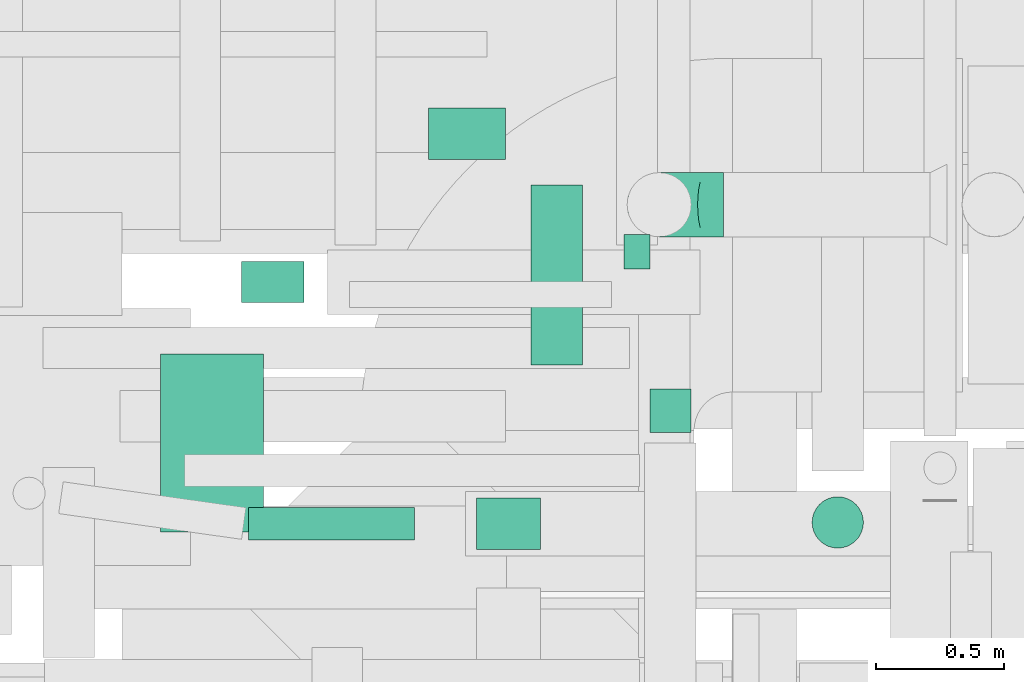
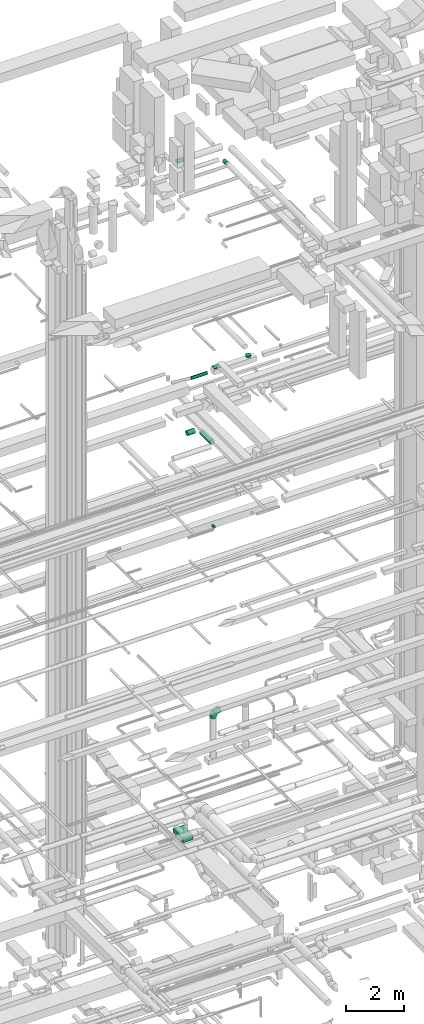
# One storey, part 274 of 337: 9 flow segments, 1 flow fitting.
"""IFC2X3 building model written with IfcOpenShell, lengths in millimetres."""

from ifc_helpers import new_model, entity, si_unit, converted_unit, derived_unit, direction, frame, origin, origin_2d_with_axis, place, context, subcontext, project, spatial, rectangle, circle, extrude, faceted_brep, source, transform, mapped, material, type_object, type_shapes, element, save


model = new_model("IFC2X3")

# Units and contexts
model_context = context("Model", 3, precision=0.01, world=origin(), true_north=direction((6.12303176911189e-17, 1.0)))
body_context = subcontext(model_context, "Body", "Model", "MODEL_VIEW")
ifc_project = project(units=[si_unit("LENGTHUNIT", "METRE", prefix="MILLI"), si_unit("AREAUNIT", "SQUARE_METRE"), si_unit("VOLUMEUNIT", "CUBIC_METRE"), converted_unit("PLANEANGLEUNIT", "DEGREE", entity("IfcRatioMeasure", 0.0174532925199433), si_unit("PLANEANGLEUNIT", "RADIAN"), dimensions=[0, 0, 0, 0, 0, 0, 0]), si_unit("MASSUNIT", "GRAM", prefix="KILO"), derived_unit("MASSDENSITYUNIT", [(si_unit("MASSUNIT", "GRAM", prefix="KILO"), 1), (si_unit("LENGTHUNIT", "METRE"), -3)]), derived_unit("MOMENTOFINERTIAUNIT", [(si_unit("LENGTHUNIT", "METRE"), 4)]), si_unit("TIMEUNIT", "SECOND"), si_unit("FREQUENCYUNIT", "HERTZ"), si_unit("THERMODYNAMICTEMPERATUREUNIT", "DEGREE_CELSIUS"), derived_unit("THERMALTRANSMITTANCEUNIT", [(si_unit("MASSUNIT", "GRAM", prefix="KILO"), 1), (si_unit("THERMODYNAMICTEMPERATUREUNIT", "KELVIN"), -1), (si_unit("TIMEUNIT", "SECOND"), -3)]), derived_unit("VOLUMETRICFLOWRATEUNIT", [(si_unit("LENGTHUNIT", "METRE"), 3), (si_unit("TIMEUNIT", "SECOND"), -1)]), derived_unit("MASSFLOWRATEUNIT", [(si_unit("MASSUNIT", "GRAM", prefix="KILO"), 1), (si_unit("TIMEUNIT", "SECOND"), -1)]), derived_unit("ROTATIONALFREQUENCYUNIT", [(si_unit("TIMEUNIT", "SECOND"), -1)]), si_unit("ELECTRICCURRENTUNIT", "AMPERE"), si_unit("ELECTRICVOLTAGEUNIT", "VOLT"), si_unit("POWERUNIT", "WATT"), si_unit("FORCEUNIT", "NEWTON", prefix="KILO"), si_unit("ILLUMINANCEUNIT", "LUX"), si_unit("LUMINOUSFLUXUNIT", "LUMEN"), si_unit("LUMINOUSINTENSITYUNIT", "CANDELA"), derived_unit("USERDEFINED", [(si_unit("MASSUNIT", "GRAM", prefix="KILO"), -1), (si_unit("LENGTHUNIT", "METRE"), -2), (si_unit("TIMEUNIT", "SECOND"), 3), (si_unit("LUMINOUSFLUXUNIT", "LUMEN"), 1)]), derived_unit("LINEARVELOCITYUNIT", [(si_unit("LENGTHUNIT", "METRE"), 1), (si_unit("TIMEUNIT", "SECOND"), -1)]), si_unit("PRESSUREUNIT", "PASCAL"), derived_unit("USERDEFINED", [(si_unit("LENGTHUNIT", "METRE"), -2), (si_unit("MASSUNIT", "GRAM", prefix="KILO"), 1), (si_unit("TIMEUNIT", "SECOND"), -2)]), derived_unit("LINEARFORCEUNIT", [(si_unit("MASSUNIT", "GRAM", prefix="KILO"), 1), (si_unit("LENGTHUNIT", "METRE"), 1), (si_unit("TIMEUNIT", "SECOND"), -2), (si_unit("LENGTHUNIT", "METRE"), -1)]), derived_unit("PLANARFORCEUNIT", [(si_unit("MASSUNIT", "GRAM", prefix="KILO"), 1), (si_unit("LENGTHUNIT", "METRE"), 1), (si_unit("TIMEUNIT", "SECOND"), -2), (si_unit("LENGTHUNIT", "METRE"), -2)])], contexts=[model_context])

# Site, building, storey
site_placement = place(None, origin())
site = spatial("IfcSite", under=ifc_project, at=site_placement, CompositionType="ELEMENT")
building_placement = place(site_placement, origin())
building = spatial("IfcBuilding", under=site, at=building_placement, CompositionType="ELEMENT")
storey_placement = place(building_placement, origin())
storey = spatial("IfcBuildingStorey", under=building, at=storey_placement, CompositionType="ELEMENT", Elevation=0.0)

# Flow segments
duct_segment_type_1 = type_object("IfcDuctSegmentType", PredefinedType="NOTDEFINED")
flow_segment_1_placement = place(storey_placement, frame((39339.82, 16031.71, 18970.0)))
element("IfcFlowSegment", 1, at=flow_segment_1_placement, inside=storey, type_object=duct_segment_type_1, context=body_context, shape_type="SweptSolid", body=[
    extrude(rectangle(XDim=249.999999999995, YDim=200.0, at=origin_2d_with_axis()), frame((125.0, 100.0, 0.0)), (0.0, 0.0, 1.0), 29.9999999999953),
])
flow_segment_2_placement = place(storey_placement, frame((38109.51, 16098.93, -700.0)))
element("IfcFlowSegment", 2, at=flow_segment_2_placement, inside=storey, type_object=duct_segment_type_1, context=body_context, shape_type="SweptSolid", body=[
    extrude(rectangle(XDim=694.499020000066, YDim=400.0, at=origin_2d_with_axis()), frame((200.0, 347.25, 0.0), z_axis=(0.0, 0.0, 1.0), x_axis=(0.0, -1.0, 0.0)), (0.0, 0.0, 1.0), 200.0),
])
duct_segment_type_2 = type_object("IfcDuctSegmentType", PredefinedType="NOTDEFINED")
flow_segment_3_placement = place(storey_placement, frame((39913.9, 17124.24, 11348.4)))
element("IfcFlowSegment", 3, at=flow_segment_3_placement, inside=storey, type_object=duct_segment_type_2, context=body_context, shape_type="SweptSolid", body=[
    extrude(circle(Radius=50.0, at=origin_2d_with_axis()), frame((51.6, 0.0, 51.6), z_axis=(0.0, 1.0, 0.0), x_axis=(1.0, 0.0, 0.0)), (0.0, 0.0, 1.0), 133.886526241199),
])
flow_segment_4_placement = place(storey_placement, frame((38451.11, 16067.41, 18785.9)))
element("IfcFlowSegment", 4, at=flow_segment_4_placement, inside=storey, type_object=duct_segment_type_2, context=body_context, shape_type="SweptSolid", body=[
    extrude(circle(Radius=62.5, at=origin_2d_with_axis()), frame((0.0, 64.1, 64.1), z_axis=(1.0, 0.0, 0.0), x_axis=(0.0, 1.0, 0.0)), (0.0, 0.0, 1.0), 646.972263338344),
])
flow_segment_5_placement = place(storey_placement, frame((40645.68, 16034.91, 18970.0)))
element("IfcFlowSegment", 5, at=flow_segment_5_placement, inside=storey, type_object=duct_segment_type_2, context=body_context, shape_type="SweptSolid", body=[
    extrude(circle(Radius=100.0, at=origin_2d_with_axis()), frame((101.6, 101.6, 0.0)), (0.0, 0.0, 1.0), 79.9999999999797),
])
flow_segment_6_placement = place(storey_placement, frame((39550.76, 16750.0, 15248.4)))
element("IfcFlowSegment", 6, at=flow_segment_6_placement, inside=storey, type_object=duct_segment_type_2, context=body_context, shape_type="SweptSolid", body=[
    extrude(circle(Radius=100.0, at=origin_2d_with_axis()), frame((101.6, 0.0, 101.6), z_axis=(0.0, 1.0, 0.0), x_axis=(1.0, 0.0, 0.0)), (0.0, 0.0, 1.0), 700.000000000014),
])
flow_segment_7_placement = place(storey_placement, frame((39152.35, 17548.41, 15248.4)))
element("IfcFlowSegment", 7, at=flow_segment_7_placement, inside=storey, type_object=duct_segment_type_2, context=body_context, shape_type="SweptSolid", body=[
    extrude(circle(Radius=100.0, at=origin_2d_with_axis()), frame((0.0, 101.6, 101.6), z_axis=(1.0, 0.0, 0.0), x_axis=(0.0, 1.0, 0.0)), (0.0, 0.0, 1.0), 300.00000000001),
])
flow_segment_8_placement = place(storey_placement, frame((40013.51, 16486.34, 27088.4)))
element("IfcFlowSegment", 8, at=flow_segment_8_placement, inside=storey, type_object=duct_segment_type_2, context=body_context, shape_type="SweptSolid", body=[
    extrude(circle(Radius=80.0, at=origin_2d_with_axis()), frame((81.6, 0.0, 81.6), z_axis=(0.0, 1.0, 0.0), x_axis=(1.0, 0.0, 0.0)), (0.0, 0.0, 1.0), 170.000000000013),
])
flow_segment_9_placement = place(storey_placement, frame((38423.89, 16990.66, 27393.41)))
element("IfcFlowSegment", 9, at=flow_segment_9_placement, inside=storey, type_object=duct_segment_type_2, context=body_context, shape_type="SweptSolid", body=[
    extrude(circle(Radius=80.0, at=origin_2d_with_axis()), frame((0.0, 81.6, 81.6), z_axis=(1.0, 0.0, 0.0), x_axis=(0.0, 1.0, 0.0)), (0.0, 0.0, 1.0), 245.000000000005),
])

# Flow fitting
ifc_material = material()
duct_fitting_type = type_object("IfcDuctFittingType", PredefinedType="NOTDEFINED", material=ifc_material)
shared_shape = source(origin(), body_context, "Body", "Brep", [
    faceted_brep([(-250.0, 0.0, -125.0), (-250.0, -32.35, -120.74), (-250.0, -62.5, -108.25), (-250.0, -88.39, -88.39), (-250.0, -108.25, -62.5), (-250.0, -120.74, -32.35), (-250.0, -125.0, 0.0), (-250.0, -120.74, 32.35), (-250.0, -108.25, 62.5), (-250.0, -88.39, 88.39), (-250.0, -62.5, 108.25), (-250.0, -32.35, 120.74), (-250.0, 0.0, 125.0), (-250.0, 32.35, 120.74), (-250.0, 62.5, 108.25), (-250.0, 88.39, 88.39), (-250.0, 108.25, 62.5), (-250.0, 120.74, 32.35), (-250.0, 125.0, 0.0), (-250.0, 120.74, -32.35), (-250.0, 108.25, -62.5), (-250.0, 88.39, -88.39), (-250.0, 62.5, -108.25), (-250.0, 32.35, -120.74), (-191.68, 32.35, 120.74), (-199.76, 62.5, 108.25), (-183.01, 0.0, 125.0), (-206.7, 88.39, 88.39), (-215.37, 120.74, 32.35), (-216.51, 125.0, 0.0), (-212.02, 108.25, 62.5), (-212.02, 108.25, -62.5), (-206.7, 88.39, -88.39), (-215.37, 120.74, -32.35), (-191.68, 32.35, -120.74), (-183.01, 0.0, -125.0), (-199.76, 62.5, -108.25), (-174.34, -32.35, -120.74), (-166.27, -62.5, -108.25), (-159.33, -88.39, -88.39), (-154.01, -108.25, -62.5), (-150.66, -120.74, -32.35), (-149.52, -125.0, 0.0), (-150.66, -120.74, 32.35), (-154.01, -108.25, 62.5), (-159.33, -88.39, 88.39), (-166.27, -62.5, 108.25), (-174.34, -32.35, 120.74), (-90.67, 90.67, 120.74), (-112.74, 112.74, 108.25), (-66.99, 66.99, 125.0), (-131.69, 131.69, 88.39), (-146.23, 146.23, 62.5), (-155.38, 155.38, 32.35), (-158.49, 158.49, 0.0), (-155.38, 155.38, -32.35), (-146.23, 146.23, -62.5), (-131.69, 131.69, -88.39), (-90.67, 90.67, -120.74), (-66.99, 66.99, -125.0), (-112.74, 112.74, -108.25), (-43.3, 43.3, -120.74), (-21.23, 21.23, -108.25), (-2.28, 2.28, -88.39), (12.26, -12.26, -62.5), (21.4, -21.4, -32.35), (24.52, -24.52, 0.0), (21.4, -21.4, 32.35), (12.26, -12.26, 62.5), (-2.28, 2.28, 88.39), (-21.23, 21.23, 108.25), (-43.3, 43.3, 120.74), (-32.35, 191.68, 120.74), (-62.5, 199.76, 108.25), (0.0, 183.01, 125.0), (-88.39, 206.7, 88.39), (-108.25, 212.02, 62.5), (-120.74, 215.37, 32.35), (-125.0, 216.51, 0.0), (-120.74, 215.37, -32.35), (-108.25, 212.02, -62.5), (-88.39, 206.7, -88.39), (-32.35, 191.68, -120.74), (0.0, 183.01, -125.0), (-62.5, 199.76, -108.25), (32.35, 174.34, -120.74), (62.5, 166.27, -108.25), (88.39, 159.33, -88.39), (108.25, 154.01, -62.5), (120.74, 150.66, -32.35), (125.0, 149.52, 0.0), (120.74, 150.66, 32.35), (108.25, 154.01, 62.5), (88.39, 159.33, 88.39), (62.5, 166.27, 108.25), (32.35, 174.34, 120.74), (-32.35, 250.0, -120.74), (-62.5, 250.0, -108.25), (-88.39, 250.0, -88.39), (-108.25, 250.0, -62.5), (-120.74, 250.0, -32.35), (-125.0, 250.0, 0.0), (-120.74, 250.0, 32.35), (-108.25, 250.0, 62.5), (-88.39, 250.0, 88.39), (-62.5, 250.0, 108.25), (-32.35, 250.0, 120.74), (0.0, 250.0, 125.0), (32.35, 250.0, 120.74), (62.5, 250.0, 108.25), (88.39, 250.0, 88.39), (108.25, 250.0, 62.5), (120.74, 250.0, 32.35), (125.0, 250.0, 0.0), (120.74, 250.0, -32.35), (108.25, 250.0, -62.5), (88.39, 250.0, -88.39), (62.5, 250.0, -108.25), (32.35, 250.0, -120.74), (0.0, 250.0, -125.0)], [[[0, 1, 2, 3, 4, 5, 6, 7, 8, 9, 10, 11, 12, 13, 14, 15, 16, 17, 18, 19, 20, 21, 22, 23]], [[24, 25, 14, 13]], [[26, 24, 13, 12]], [[14, 25, 27, 15]], [[28, 29, 18, 17]], [[30, 28, 17, 16]], [[15, 27, 30, 16]], [[20, 31, 32, 21]], [[33, 31, 20, 19]], [[18, 29, 33, 19]], [[34, 35, 0, 23]], [[36, 34, 23, 22]], [[21, 32, 36, 22]], [[1, 0, 35, 37]], [[2, 1, 37, 38]], [[38, 39, 3, 2]], [[5, 4, 40, 41]], [[6, 5, 41, 42]], [[39, 40, 4, 3]], [[6, 42, 43, 7]], [[7, 43, 44, 8]], [[8, 44, 45, 9]], [[9, 45, 46, 10]], [[10, 46, 47, 11]], [[26, 12, 11, 47]], [[48, 49, 25, 24]], [[50, 48, 24, 26]], [[27, 25, 49, 51]], [[52, 53, 28, 30]], [[51, 52, 30, 27]], [[29, 28, 53, 54]], [[55, 56, 31, 33]], [[54, 55, 33, 29]], [[32, 31, 56, 57]], [[58, 59, 35, 34]], [[60, 58, 34, 36]], [[57, 60, 36, 32]], [[37, 35, 59, 61]], [[38, 37, 61, 62]], [[39, 38, 62, 63]], [[41, 40, 64, 65]], [[42, 41, 65, 66]], [[63, 64, 40, 39]], [[43, 42, 66, 67]], [[44, 43, 67, 68]], [[68, 69, 45, 44]], [[46, 45, 69, 70]], [[47, 46, 70, 71]], [[26, 47, 71, 50]], [[72, 73, 49, 48]], [[74, 72, 48, 50]], [[51, 49, 73, 75]], [[76, 77, 53, 52]], [[75, 76, 52, 51]], [[54, 53, 77, 78]], [[79, 80, 56, 55]], [[78, 79, 55, 54]], [[57, 56, 80, 81]], [[82, 83, 59, 58]], [[84, 82, 58, 60]], [[81, 84, 60, 57]], [[61, 59, 83, 85]], [[62, 61, 85, 86]], [[63, 62, 86, 87]], [[65, 64, 88, 89]], [[66, 65, 89, 90]], [[87, 88, 64, 63]], [[67, 66, 90, 91]], [[68, 67, 91, 92]], [[92, 93, 69, 68]], [[70, 69, 93, 94]], [[71, 70, 94, 95]], [[50, 71, 95, 74]], [[96, 97, 98, 99, 100, 101, 102, 103, 104, 105, 106, 107, 108, 109, 110, 111, 112, 113, 114, 115, 116, 117, 118, 119]], [[72, 74, 107, 106]], [[73, 72, 106, 105]], [[75, 73, 105, 104]], [[77, 76, 103, 102]], [[78, 77, 102, 101]], [[75, 104, 103, 76]], [[78, 101, 100, 79]], [[79, 100, 99, 80]], [[80, 99, 98, 81]], [[84, 97, 96, 82]], [[82, 96, 119, 83]], [[84, 81, 98, 97]], [[83, 119, 118, 85]], [[85, 118, 117, 86]], [[116, 87, 86, 117]], [[88, 115, 114, 89]], [[89, 114, 113, 90]], [[115, 88, 87, 116]], [[91, 90, 113, 112]], [[92, 91, 112, 111]], [[111, 110, 93, 92]], [[95, 94, 109, 108]], [[74, 95, 108, 107]], [[110, 109, 94, 93]]]),
])
type_shapes(duct_fitting_type, [shared_shape])
flow_fitting_placement = place(storey_placement, frame((40051.92, 17374.28, 3435.82), z_axis=(0.0, -1.0, 0.0), x_axis=(-1.0, 0.0, 0.0)))
element("IfcFlowFitting", 10, at=flow_fitting_placement, inside=storey, type_object=duct_fitting_type, material=ifc_material, context=body_context, shape_type="MappedRepresentation", body=[
    mapped(shared_shape, transform((0.0, 0.0, 0.0), scale=1.0)),
])

save(model, "model.ifc")
